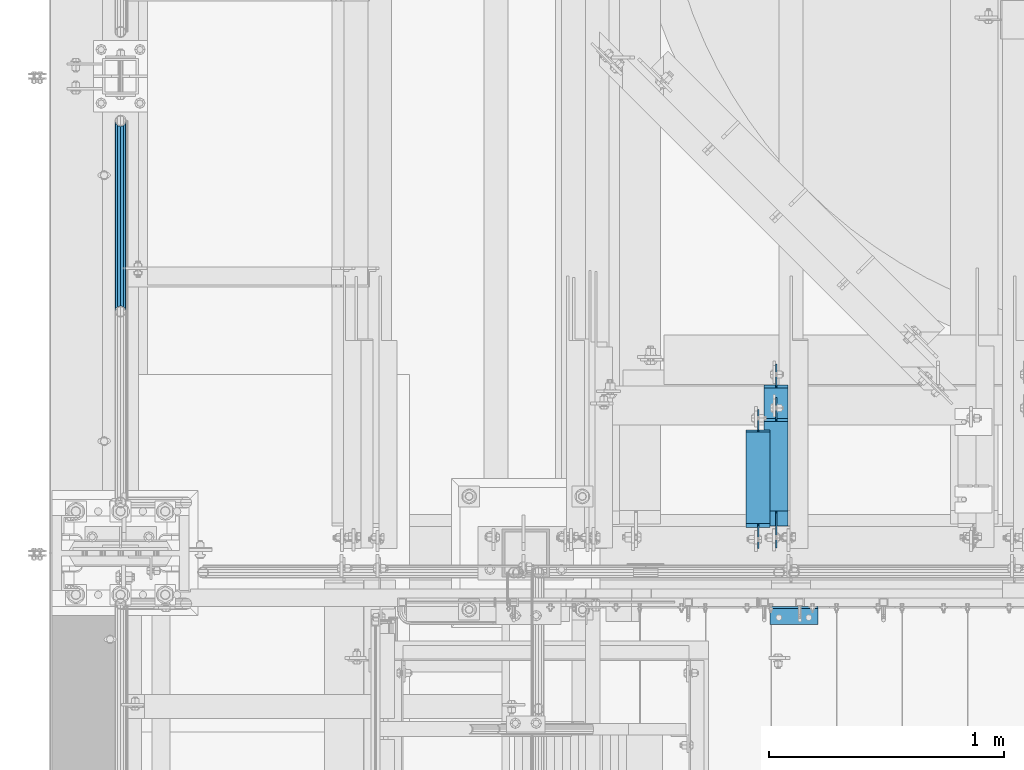
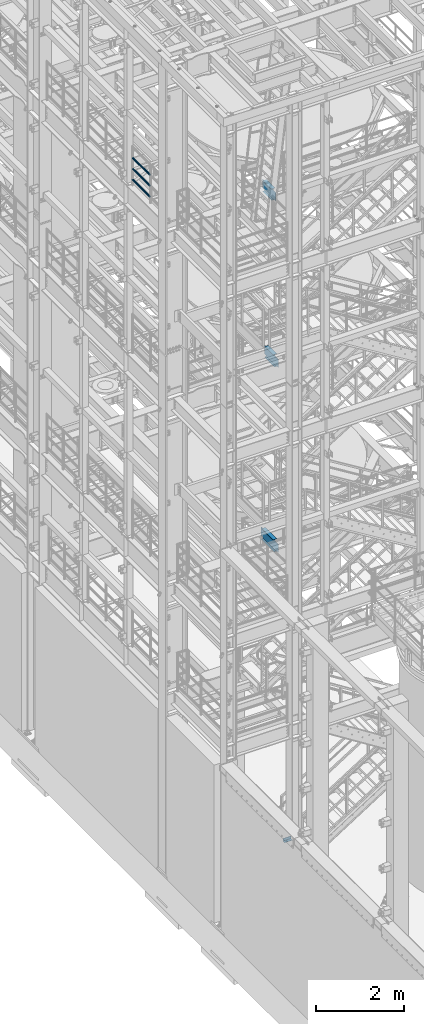
# One storey, part 1178 of 1876: 7 beams, 5 elements without a shape of their own.
"""IFC2X3 building model written with IfcOpenShell, lengths in millimetres."""

from ifc_helpers import new_model, si_unit, frame, origin_with_axes, place, context, subcontext, project, spatial, faceted_brep, material, type_object, element, aggregate, save


model = new_model("IFC2X3")

# Units and contexts
model_context = context("Model", 3, precision=1e-05, world=origin_with_axes())
body_context = subcontext(model_context, "Body", "Model", "MODEL_VIEW")
ifc_project = project(units=[si_unit("LENGTHUNIT", "METRE", prefix="MILLI"), si_unit("AREAUNIT", "SQUARE_METRE"), si_unit("VOLUMEUNIT", "CUBIC_METRE"), si_unit("MASSUNIT", "GRAM", prefix="KILO"), si_unit("TIMEUNIT", "SECOND"), si_unit("PLANEANGLEUNIT", "RADIAN"), si_unit("SOLIDANGLEUNIT", "STERADIAN"), si_unit("THERMODYNAMICTEMPERATUREUNIT", "DEGREE_CELSIUS"), si_unit("LUMINOUSINTENSITYUNIT", "LUMEN")], contexts=[model_context])

# Site, building, storey
site_placement = place(None, origin_with_axes())
site = spatial("IfcSite", under=ifc_project, at=site_placement, CompositionType="ELEMENT")
building_placement = place(site_placement, origin_with_axes())
building = spatial("IfcBuilding", under=site, at=building_placement, Name="Undefined", CompositionType="ELEMENT")
storey_placement = place(building_placement, origin_with_axes())
storey = spatial("IfcBuildingStorey", under=building, at=storey_placement, Name="Undefined", CompositionType="ELEMENT", Elevation=0.0)

# Assembly, beams
assembly_1_placement = place(storey_placement, origin_with_axes())
assembly_1 = element("IfcElementAssembly", 1, at=assembly_1_placement, inside=storey, Name="RAIL", AssemblyPlace="NOTDEFINED", PredefinedType="RIGID_FRAME")
ifc_material_1 = material()
beam_type_1 = type_object("IfcBeamType", Name="PIPE1-1/2SCH40", PredefinedType="NOTDEFINED")
beam_1_placement = place(assembly_1_placement, frame((-1.81898940354582e-12, -2729.3062, 18145.125), z_axis=(0.0, 0.0, 1.0), x_axis=(0.0, -1.0, 0.0)))
beam_1 = element("IfcBeam", 2, at=beam_1_placement, type_object=beam_type_1, material=ifc_material_1, Name="RAIL", ObjectType="PIPE1-1/2SCH40", context=body_context, shape_type="Brep", body=[
    faceted_brep([(792.499707006684, -12.0649999999996, 20.8971929933177), (792.499707006684, -12.0650000000314, 15.8661214311469), (792.006278568813, -10.2235000000001, 17.7076214311819), (789.266900000001, -9.09494701772928e-13, 20.4470000000001), (789.266900000001, -9.09494701772928e-13, 24.130000000001), (792.00627856883, 10.2235000000001, 17.7076214311819), (792.499707006684, 12.0649999999678, 15.8661214312124), (792.499707006684, 12.0649999999996, 20.8971929933177), (813.396900000002, 24.1300000000001, 0.0), (801.331900000001, 20.8971929933186, 12.0649999999987), (801.331900000001, 20.8971929933186, -12.0649999999987), (798.142328437896, 17.7076214311801, 10.2235000000001), (800.881707006714, 20.4470000000001, 0.0), (798.142328437896, 17.7076214311801, -10.2235000000001), (792.499707006684, 12.0649999999678, -15.8661214312124), (792.499707006684, 12.0649999999996, -20.8971929933177), (792.00627856883, 10.2235000000001, -17.7076214311819), (789.266900000001, 0.0, -20.4470000000001), (789.266900000001, 0.0, -24.130000000001), (792.499707006684, -12.0650000000314, -15.8661214311469), (792.499707006684, -12.0649999999996, -20.8971929933177), (792.006278568813, -10.2235000000001, -17.7076214311819), (813.396900000002, -24.1300000000319, 0.0), (801.331900000001, -20.8971929933186, -12.0649999999987), (801.331900000001, -20.8971929933186, 12.0649999999987), (798.142328437831, -17.7076214311801, -10.2235000000001), (800.881707006651, -20.4470000000001, 0.0), (798.142328437831, -17.7076214311801, 10.2235000000001), (12.0650000000064, -20.8971929933177, -12.0649999999987), (20.8971929933249, -12.0650000000005, -20.8971929933177), (0.0, 24.1299999999992, 0.0), (12.0650000000064, 20.8971929933177, -12.0649999999987), (12.0650000000064, 20.8971929933177, 12.0649999999987), (20.8971929933249, 12.0650000000005, 20.8971929933177), (24.1300000000064, 0.0, 24.130000000001), (20.8971929933249, 12.0650000000005, -20.8971929933177), (24.1300000000063, 0.0, -24.130000000001), (24.1300000000063, 0.0, -20.4470000000001), (20.8971929933249, -12.0650000000005, -15.8661214311796), (21.3906214311868, -10.2235000000001, -17.7076214311819), (21.3906214311868, 10.2235000000001, -17.7076214311819), (20.8971929933249, 12.0650000000005, -15.8661214311796), (15.2545715621445, 17.7076214311801, -10.2235000000001), (12.5151929933249, 20.4470000000001, 0.0), (15.2545715621445, 17.7076214311801, 10.2235000000001), (20.8971929933249, 12.0650000000005, 15.8661214311796), (21.3906214311868, 10.2235000000001, 17.7076214311819), (24.1300000000064, 0.0, 20.4470000000001), (21.3906214311868, -10.2235000000001, 17.7076214311819), (20.8971929933249, -12.0650000000005, 15.8661214311796), (20.8971929933249, -12.0650000000005, 20.8971929933177), (12.0650000000064, -20.8971929933177, 12.0649999999987), (0.0, -24.1299999999992, 0.0), (15.2545715621445, -17.7076214311801, 10.2235000000001), (12.5151929933249, -20.4470000000001, 0.0), (15.2545715621445, -17.7076214311801, -10.2235000000001)], [[[0, 1, 2, 3, 4]], [[4, 3, 5, 6, 7]], [[8, 9, 10]], [[7, 6, 11, 12, 13, 14, 15, 10, 9]], [[16, 17, 18, 15, 14]], [[19, 20, 18, 17, 21]], [[22, 23, 24]], [[24, 23, 20, 19, 25, 26, 27, 1, 0]], [[28, 29, 20, 23]], [[30, 31, 32]], [[33, 34, 4, 7]], [[32, 33, 7, 9]], [[30, 32, 9, 8]], [[31, 30, 8, 10]], [[35, 31, 10, 15]], [[36, 35, 15, 18]], [[29, 36, 18, 20]], [[37, 36, 29, 38, 39]], [[40, 41, 35, 36, 37]], [[32, 31, 35, 41, 42, 43, 44, 45, 33]], [[33, 45, 46, 47, 34]], [[34, 47, 48, 49, 50]], [[34, 50, 0, 4]], [[50, 51, 24, 0]], [[51, 52, 22, 24]], [[52, 28, 23, 22]], [[51, 28, 52]], [[50, 49, 53, 54, 55, 38, 29, 28, 51]], [[55, 54, 26, 25]], [[21, 39, 38, 55, 25, 19]], [[37, 39, 21, 17]], [[40, 37, 17, 16]], [[42, 41, 40, 16, 14, 13]], [[43, 42, 13, 12]], [[44, 43, 12, 11]], [[5, 46, 45, 44, 11, 6]], [[47, 46, 5, 3]], [[48, 47, 3, 2]], [[53, 49, 48, 2, 1, 27]], [[54, 53, 27, 26]]]),
])
beam_2_placement = place(assembly_1_placement, frame((-1.81898940354586e-12, -3542.7031, 18449.925), z_axis=(0.0, 0.0, -1.0), x_axis=(0.0, 1.0, 0.0)))
beam_2 = element("IfcBeam", 3, at=beam_2_placement, type_object=beam_type_1, material=ifc_material_1, Name="RAIL", ObjectType="PIPE1-1/2SCH40", context=body_context, shape_type="Brep", body=[
    faceted_brep([(0.0, 24.1299999999992, 0.0), (12.0650000000064, 20.8971929933177, -12.0649999999987), (12.0650000000064, 20.8971929933177, 12.0649999999987), (12.0650000000064, -20.8971929933177, 12.0649999999987), (12.0650000000064, -20.8971929933177, -12.0649999999987), (0.0, -24.1299999999992, 0.0), (20.8971929933249, -12.0650000000005, 20.8971929933177), (20.8971929933249, -12.0650000000005, 15.8661214311796), (15.2545715621445, -17.7076214311801, 10.2235000000001), (12.5151929933249, -20.4470000000001, 0.0), (15.2545715621445, -17.7076214311801, -10.2235000000001), (20.8971929933249, -12.0650000000005, -15.8661214311796), (20.8971929933249, -12.0650000000005, -20.8971929933177), (24.1300000000063, 0.0, -20.4470000000001), (24.1300000000063, 0.0, -24.130000000001), (21.3906214311868, -10.2235000000001, -17.7076214311819), (21.3906214311868, 10.2235000000001, -17.7076214311819), (20.8971929933249, 12.0650000000005, -15.8661214311796), (20.8971929933249, 12.0650000000005, -20.8971929933177), (15.2545715621445, 17.7076214311801, -10.2235000000001), (12.5151929933249, 20.4470000000001, 0.0), (15.2545715621445, 17.7076214311801, 10.2235000000001), (20.8971929933249, 12.0650000000005, 15.8661214311796), (20.8971929933249, 12.0650000000005, 20.8971929933177), (21.3906214311868, 10.2235000000001, 17.7076214311819), (24.1300000000064, 0.0, 20.4470000000001), (24.1300000000064, 0.0, 24.130000000001), (21.3906214311868, -10.2235000000001, 17.7076214311819), (813.396900000002, 24.1300000000001, 0.0), (801.331900000001, 20.8971929933186, -12.0649999999987), (792.499707006684, 12.0649999999996, -20.8971929933177), (813.396900000002, -24.1300000000319, 0.0), (801.331900000001, -20.8971929933186, -12.0649999999987), (801.331900000001, -20.8971929933186, 12.0649999999987), (792.499707006684, -12.0649999999996, 20.8971929933177), (792.499707006684, -12.0649999999996, -20.8971929933177), (789.266900000001, 0.0, -24.130000000001), (792.00627856883, 10.2235000000001, -17.7076214311819), (789.266900000001, 0.0, -20.4470000000001), (792.499707006684, 12.0649999999678, -15.8661214312124), (792.499707006684, -12.0650000000314, -15.8661214311469), (792.006278568813, -10.2235000000001, -17.7076214311819), (798.142328437831, -17.7076214311801, -10.2235000000001), (800.881707006651, -20.4470000000001, 0.0), (798.142328437831, -17.7076214311801, 10.2235000000001), (792.499707006684, -12.0650000000314, 15.8661214311469), (792.006278568813, -10.2235000000001, 17.7076214311819), (789.266900000001, -9.09494701772928e-13, 20.4470000000001), (789.266900000001, -9.09494701772928e-13, 24.130000000001), (792.499707006684, 12.0649999999996, 20.8971929933177), (801.331900000001, 20.8971929933186, 12.0649999999987), (792.499707006684, 12.0649999999678, 15.8661214312124), (798.142328437896, 17.7076214311801, 10.2235000000001), (800.881707006714, 20.4470000000001, 0.0), (798.142328437896, 17.7076214311801, -10.2235000000001), (792.00627856883, 10.2235000000001, 17.7076214311819)], [[[0, 1, 2]], [[3, 4, 5]], [[6, 7, 8, 9, 10, 11, 12, 4, 3]], [[13, 14, 12, 11, 15]], [[16, 17, 18, 14, 13]], [[2, 1, 18, 17, 19, 20, 21, 22, 23]], [[23, 22, 24, 25, 26]], [[26, 25, 27, 7, 6]], [[1, 0, 28, 29]], [[18, 1, 29, 30]], [[31, 32, 33]], [[6, 3, 33, 34]], [[3, 5, 31, 33]], [[5, 4, 32, 31]], [[4, 12, 35, 32]], [[12, 14, 36, 35]], [[14, 18, 30, 36]], [[37, 38, 36, 30, 39]], [[40, 35, 36, 38, 41]], [[33, 32, 35, 40, 42, 43, 44, 45, 34]], [[34, 45, 46, 47, 48]], [[26, 6, 34, 48]], [[2, 23, 49, 50]], [[23, 26, 48, 49]], [[0, 2, 50, 28]], [[28, 50, 29]], [[49, 51, 52, 53, 54, 39, 30, 29, 50]], [[48, 47, 55, 51, 49]], [[25, 24, 55, 47]], [[55, 24, 22, 21, 52, 51]], [[21, 20, 53, 52]], [[20, 19, 54, 53]], [[19, 17, 16, 37, 39, 54]], [[16, 13, 38, 37]], [[13, 15, 41, 38]], [[41, 15, 11, 10, 42, 40]], [[10, 9, 43, 42]], [[9, 8, 44, 43]], [[8, 7, 27, 46, 45, 44]], [[27, 25, 47, 46]]]),
])
beam_3_placement = place(assembly_1_placement, frame((-1.81898940354586e-12, -3542.7031, 18754.725), z_axis=(0.0, 0.0, -1.0), x_axis=(0.0, 1.0, 0.0)))
beam_3 = element("IfcBeam", 4, at=beam_3_placement, type_object=beam_type_1, material=ifc_material_1, Name="RAIL", ObjectType="PIPE1-1/2SCH40", context=body_context, shape_type="Brep", body=[
    faceted_brep([(0.0, 24.1299999999992, 0.0), (12.0650000000064, 20.8971929933177, -12.0649999999987), (12.0650000000064, 20.8971929933177, 12.0649999999987), (12.0650000000064, -20.8971929933177, 12.0649999999987), (12.0650000000064, -20.8971929933177, -12.0649999999987), (0.0, -24.1299999999992, 0.0), (20.8971929933249, -12.0650000000005, 20.8971929933177), (20.8971929933249, -12.0650000000005, 15.8661214311796), (15.2545715621445, -17.7076214311801, 10.2235000000001), (12.5151929933249, -20.4470000000001, 0.0), (15.2545715621445, -17.7076214311801, -10.2235000000001), (20.8971929933249, -12.0650000000005, -15.8661214311796), (20.8971929933249, -12.0650000000005, -20.8971929933177), (24.1300000000063, 0.0, -20.4470000000001), (24.1300000000063, 0.0, -24.130000000001), (21.3906214311868, -10.2235000000001, -17.7076214311819), (21.3906214311868, 10.2235000000001, -17.7076214311819), (20.8971929933249, 12.0650000000005, -15.8661214311796), (20.8971929933249, 12.0650000000005, -20.8971929933177), (15.2545715621445, 17.7076214311801, -10.2235000000001), (12.5151929933249, 20.4470000000001, 0.0), (15.2545715621445, 17.7076214311801, 10.2235000000001), (20.8971929933249, 12.0650000000005, 15.8661214311796), (20.8971929933249, 12.0650000000005, 20.8971929933177), (21.3906214311868, 10.2235000000001, 17.7076214311819), (24.1300000000064, 0.0, 20.4470000000001), (24.1300000000064, 0.0, 24.130000000001), (21.3906214311868, -10.2235000000001, 17.7076214311819), (813.396900000002, 24.1300000000001, 0.0), (801.331900000001, 20.8971929933186, -12.0649999999987), (792.499707006684, 12.0649999999996, -20.8971929933177), (813.396900000002, -24.1300000000319, 0.0), (801.331900000001, -20.8971929933186, -12.0649999999987), (801.331900000001, -20.8971929933186, 12.0649999999987), (792.499707006684, -12.0649999999996, 20.8971929933177), (792.499707006684, -12.0649999999996, -20.8971929933177), (789.266900000001, 0.0, -24.130000000001), (792.00627856883, 10.2235000000001, -17.7076214311819), (789.266900000001, 0.0, -20.4470000000001), (792.499707006684, 12.0649999999678, -15.8661214312124), (792.499707006684, -12.0650000000314, -15.8661214311469), (792.006278568813, -10.2235000000001, -17.7076214311819), (798.142328437831, -17.7076214311801, -10.2235000000001), (800.881707006651, -20.4470000000001, 0.0), (798.142328437831, -17.7076214311801, 10.2235000000001), (792.499707006684, -12.0650000000314, 15.8661214311469), (792.006278568813, -10.2235000000001, 17.7076214311819), (789.266900000001, -9.09494701772928e-13, 20.4470000000001), (789.266900000001, -9.09494701772928e-13, 24.130000000001), (792.499707006684, 12.0649999999996, 20.8971929933177), (801.331900000001, 20.8971929933186, 12.0649999999987), (792.499707006684, 12.0649999999678, 15.8661214312124), (798.142328437896, 17.7076214311801, 10.2235000000001), (800.881707006714, 20.4470000000001, 0.0), (798.142328437896, 17.7076214311801, -10.2235000000001), (792.00627856883, 10.2235000000001, 17.7076214311819)], [[[0, 1, 2]], [[3, 4, 5]], [[6, 7, 8, 9, 10, 11, 12, 4, 3]], [[13, 14, 12, 11, 15]], [[16, 17, 18, 14, 13]], [[2, 1, 18, 17, 19, 20, 21, 22, 23]], [[23, 22, 24, 25, 26]], [[26, 25, 27, 7, 6]], [[1, 0, 28, 29]], [[18, 1, 29, 30]], [[31, 32, 33]], [[6, 3, 33, 34]], [[3, 5, 31, 33]], [[5, 4, 32, 31]], [[4, 12, 35, 32]], [[12, 14, 36, 35]], [[14, 18, 30, 36]], [[37, 38, 36, 30, 39]], [[40, 35, 36, 38, 41]], [[33, 32, 35, 40, 42, 43, 44, 45, 34]], [[34, 45, 46, 47, 48]], [[26, 6, 34, 48]], [[2, 23, 49, 50]], [[23, 26, 48, 49]], [[0, 2, 50, 28]], [[28, 50, 29]], [[49, 51, 52, 53, 54, 39, 30, 29, 50]], [[48, 47, 55, 51, 49]], [[25, 24, 55, 47]], [[55, 24, 22, 21, 52, 51]], [[21, 20, 53, 52]], [[20, 19, 54, 53]], [[19, 17, 16, 37, 39, 54]], [[16, 13, 38, 37]], [[13, 15, 41, 38]], [[41, 15, 11, 10, 42, 40]], [[10, 9, 43, 42]], [[9, 8, 44, 43]], [[8, 7, 27, 46, 45, 44]], [[27, 25, 47, 46]]]),
])
aggregate(assembly_1, [beam_1, beam_2, beam_3])

# Assembly, beam
assembly_2_placement = place(storey_placement, origin_with_axes())
assembly_2 = element("IfcElementAssembly", 5, at=assembly_2_placement, inside=storey, Name="BEAM", AssemblyPlace="NOTDEFINED", PredefinedType="RIGID_FRAME")
ifc_material_2 = material(Name="STEEL/A992")
beam_type_2 = type_object("IfcBeamType", Name="W12X16", PredefinedType="NOTDEFINED")
beam_4_placement = place(assembly_2_placement, frame((2717.8, -4572.0, 17830.8), z_axis=(0.0, 0.0, 1.0), x_axis=(0.0, 1.0, 0.0)))
beam_4 = element("IfcBeam", 6, at=beam_4_placement, type_object=beam_type_2, material=ifc_material_2, Name="BEAM", ObjectType="W12X16", context=body_context, shape_type="Brep", body=[
    faceted_brep([(523.875, -3.17500000000018, -146.049999999999), (523.875, -50.8000000000002, -146.049999999999), (523.875, -50.8000000000002, -152.400000000001), (523.875, 50.8000000000002, -152.400000000001), (523.875, 50.8000000000002, -146.049999999999), (523.875, 3.17500001640747, -146.049999999999), (523.875, 3.17500003437635, -139.699999809272), (523.875, -3.17500000000018, -139.699999809272), (524.841729922588, 3.17500003361238, -134.839920291226), (524.841729922588, -3.17500000000018, -134.839920291226), (527.594743823066, 3.17500003295299, -130.719743823072), (527.594743823066, -3.17500000000018, -130.719743823072), (531.714920291219, 3.17500003250007, -127.966729922595), (531.714920291219, -3.17500000000018, -127.966729922595), (536.574999809265, 3.1750000323218, -127.000000000007), (536.574999809265, -3.17500000000018, -127.000000000007), (612.775, -3.17500000000018, -127.000000000007), (612.775, 3.17500000000018, -127.000000000007), (126.20625, 3.17499999999995, 146.049999999999), (126.20625, 50.8, 146.049999999999), (515.9375, 50.8000000000002, 146.049999999999), (515.9375, 3.17500000000018, 146.049999999999), (108.74375, -3.17499999999995, -139.699999809261), (108.74375, 3.17500002570978, -139.699999809261), (108.74375, 3.17500009516311, -146.049999999999), (108.74375, 50.8, -146.049999999999), (108.74375, 50.8, -152.400000000001), (108.74375, -50.8, -152.400000000001), (108.74375, -50.8, -146.049999999999), (108.74375, -3.17499999999995, -146.049999999999), (107.777020077412, -3.17499999999995, -134.839920291215), (107.777020077412, 3.17500002492102, -134.839920291215), (105.024006176934, -3.17499999999995, -130.719743823061), (105.024006176934, 3.17500002425209, -130.719743823061), (100.90382970878, -3.17499999999995, -127.966729922584), (100.90382970878, 3.17500002380461, -127.966729922584), (96.0437501907345, -3.17499999999995, -126.999999999996), (96.0437501907345, 3.17500002364682, -126.999999999996), (19.84375, -3.17499999999995, -126.999999999996), (19.84375, 3.17499999999995, -126.999999999996), (19.84375, -3.17499999999995, 107.950000000004), (19.84375, 3.17499999999995, 107.950000000004), (113.506250190735, -3.17499999999995, 107.950000000004), (113.506250190735, 3.17499998606149, 107.950000000004), (118.366329708781, -3.17499999999995, 108.916729922592), (118.366329708781, 3.17499998590552, 108.916729922592), (122.486506176934, -3.17499999999995, 111.669743823069), (122.486506176934, 3.17499998546009, 111.669743823069), (125.239520077413, -3.17499999999995, 115.789920291223), (125.239520077413, 3.17499998479298, 115.789920291223), (126.20625, -3.17499999999995, 120.64999980927), (126.20625, 3.17499998400558, 120.64999980927), (126.20625, 50.8, 152.400000000001), (126.20625, -50.8, 152.400000000001), (515.9375, -50.8000000000002, 152.400000000001), (515.9375, 50.8000000000002, 152.400000000001), (126.20625, -50.8, 146.049999999999), (515.9375, -50.8000000000002, 146.049999999999), (126.20625, -3.17499999999995, 146.049999999999), (515.9375, -3.17500000000018, 146.049999999999), (515.9375, -3.17500000000018, 133.349999809259), (515.9375, 3.17499999236406, 133.349999809259), (516.904229922588, -3.17500000000018, 128.489920291213), (516.904229922588, 3.17499999310803, 128.489920291213), (519.657243823066, -3.17500000000018, 124.369743823059), (519.657243823066, 3.17499999372922, 124.369743823059), (523.777420291219, -3.17500000000018, 121.616729922582), (523.777420291219, 3.17499999413303, 121.616729922582), (528.637499809265, -3.17500000000018, 120.649999999994), (528.637499809265, 3.17499999425763, 120.649999999994), (612.775, -3.17500000000018, 120.649999999994), (612.775, 3.17500000000018, 120.649999999994)], [[[0, 1, 2, 3, 4, 5, 6, 7]], [[7, 6, 8, 9]], [[9, 8, 10, 11]], [[11, 10, 12, 13]], [[13, 12, 14, 15]], [[16, 15, 14, 17]], [[18, 19, 20, 21]], [[22, 23, 24, 25, 26, 27, 28, 29]], [[30, 31, 23, 22]], [[32, 33, 31, 30]], [[34, 35, 33, 32]], [[36, 37, 35, 34]], [[38, 39, 37, 36]], [[40, 41, 39, 38]], [[42, 43, 41, 40]], [[44, 45, 43, 42]], [[46, 47, 45, 44]], [[48, 49, 47, 46]], [[50, 51, 49, 48]], [[52, 53, 54, 55]], [[53, 56, 57, 54]], [[56, 58, 59, 57]], [[53, 52, 19, 18, 51, 50, 58, 56]], [[19, 52, 55, 20]], [[54, 57, 59, 60, 61, 21, 20, 55]], [[62, 63, 61, 60]], [[64, 65, 63, 62]], [[66, 67, 65, 64]], [[68, 69, 67, 66]], [[70, 71, 69, 68]], [[71, 70, 16, 17]], [[12, 10, 8, 6, 5, 24, 23, 31, 33, 35, 37, 39, 41, 43, 45, 47, 49, 51, 18, 21, 61, 63, 65, 67, 69, 71, 17, 14]], [[25, 24, 5, 4]], [[26, 25, 4, 3]], [[27, 26, 3, 2]], [[28, 27, 2, 1]], [[29, 28, 1, 0]], [[70, 68, 66, 64, 62, 60, 59, 58, 50, 48, 46, 44, 42, 40, 38, 36, 34, 32, 30, 22, 29, 0, 7, 9, 11, 13, 15, 16]]]),
])
aggregate(assembly_2, [beam_4])

assembly_3_placement = place(storey_placement, origin_with_axes())
assembly_3 = element("IfcElementAssembly", 7, at=assembly_3_placement, inside=storey, Name="BEAM", AssemblyPlace="NOTDEFINED", PredefinedType="RIGID_FRAME")
beam_5_placement = place(assembly_3_placement, frame((2794.0, -4572.0, 13157.2), z_axis=(0.0, 0.0, 1.0), x_axis=(0.0, 1.0, 0.0)))
beam_5 = element("IfcBeam", 8, at=beam_5_placement, type_object=beam_type_2, material=ifc_material_2, Name="BEAM", ObjectType="W12X16", context=body_context, shape_type="Brep", body=[
    faceted_brep([(573.881250000001, -3.17500000000018, -146.049999999999), (573.881250000001, -50.8000000000002, -146.049999999999), (573.881250000001, -50.8000000000002, -152.4), (573.881250000001, 50.8000000000002, -152.4), (573.881250000001, 50.8000000000002, -146.049999999999), (573.881250000001, 3.17500000000018, -146.049999999999), (573.881250000001, 3.17500000000018, -139.699999809265), (573.881250000001, -3.17500000000018, -139.699999809265), (574.847979922589, 3.17500000000018, -134.839920291219), (574.847979922589, -3.17500000000018, -134.839920291219), (577.600993823067, 3.17500000000018, -130.719743823065), (577.600993823067, -3.17500000000018, -130.719743823065), (581.72117029122, 3.17500000000018, -127.966729922588), (581.72117029122, -3.17500000000018, -127.966729922588), (586.581249809266, 3.17500000000018, -127.0), (586.581249809266, -3.17500000000018, -127.0), (662.78125, -3.17500000000018, -127.0), (662.78125, 3.17500000000018, -127.0), (179.3875, 3.17500000000018, 146.049999999999), (179.3875, 50.8000000000002, 146.049999999999), (561.181250000001, 50.8000000000002, 146.049999999999), (561.181250000001, 3.17500000000018, 146.049999999999), (115.8875, -3.17500000000018, -139.699999809263), (115.8875, 3.17500000000018, -139.699999809263), (115.8875, 3.17500000000018, -146.049999999999), (115.8875, 50.8000000000002, -146.049999999999), (115.8875, 50.8000000000002, -152.4), (115.8875, -50.8000000000002, -152.4), (115.8875, -50.8000000000002, -146.049999999999), (115.8875, -3.17500000000018, -146.049999999999), (114.920770077412, -3.17500000000018, -134.839920291217), (114.920770077412, 3.17500000000018, -134.839920291217), (112.167756176934, -3.17500000000018, -130.719743823063), (112.167756176934, 3.17500000000018, -130.719743823063), (108.04757970878, -3.17500000000018, -127.966729922586), (108.04757970878, 3.17500000000018, -127.966729922586), (103.187500190735, -3.17500000000018, -126.999999999998), (103.187500190735, 3.17500000000018, -126.999999999998), (20.6374999999998, -3.17500000000018, -126.999999999998), (20.6374999999998, 3.17500000000018, -126.999999999998), (20.6374999999998, -3.17500000000018, 101.600000000002), (20.6374999999998, 3.17500000000018, 101.600000000002), (166.687500190735, -3.17500000000018, 101.600000000002), (166.687500190735, 3.17500000000018, 101.600000000002), (171.54757970878, -3.17500000000018, 102.56672992259), (171.54757970878, 3.17500000000018, 102.56672992259), (175.667756176934, -3.17500000000018, 105.319743823067), (175.667756176934, 3.17500000000018, 105.319743823067), (178.420770077412, -3.17500000000018, 109.439920291221), (178.420770077412, 3.17500000000018, 109.439920291221), (179.3875, -3.17500000000018, 114.299999809267), (179.3875, 3.17500000000018, 114.299999809267), (179.3875, -50.8000000000002, 152.4), (179.3875, 50.8000000000002, 152.4), (179.3875, -3.17500000000018, 146.049999999999), (179.3875, -50.8000000000002, 146.049999999999), (561.181250000001, -3.17500000000018, 146.049999999999), (561.181250000001, -50.8000000000002, 146.049999999999), (561.181250000001, -50.8000000000002, 152.4), (561.181250000001, 50.8000000000002, 152.4), (561.181250000001, -3.17500000000018, 133.349999809265), (561.181250000001, 3.17500000000018, 133.349999809265), (562.147979922589, -3.17500000000018, 128.489920291218), (562.147979922589, 3.17500000000018, 128.489920291218), (564.900993823067, -3.17500000000018, 124.369743823065), (564.900993823067, 3.17500000000018, 124.369743823065), (569.021170291221, -3.17500000000018, 121.616729922587), (569.021170291221, 3.17500000000018, 121.616729922587), (573.881249809266, -3.17500000000018, 120.65), (573.881249809266, 3.17500000000018, 120.65), (662.78125, -3.17500000000018, 120.65), (662.78125, 3.17500000000018, 120.65)], [[[0, 1, 2, 3, 4, 5, 6, 7]], [[7, 6, 8, 9]], [[9, 8, 10, 11]], [[11, 10, 12, 13]], [[13, 12, 14, 15]], [[16, 15, 14, 17]], [[18, 19, 20, 21]], [[22, 23, 24, 25, 26, 27, 28, 29]], [[30, 31, 23, 22]], [[32, 33, 31, 30]], [[34, 35, 33, 32]], [[36, 37, 35, 34]], [[38, 39, 37, 36]], [[40, 41, 39, 38]], [[42, 43, 41, 40]], [[44, 45, 43, 42]], [[46, 47, 45, 44]], [[48, 49, 47, 46]], [[50, 51, 49, 48]], [[52, 53, 19, 18, 51, 50, 54, 55]], [[55, 54, 56, 57]], [[52, 55, 57, 58]], [[53, 52, 58, 59]], [[19, 53, 59, 20]], [[58, 57, 56, 60, 61, 21, 20, 59]], [[62, 63, 61, 60]], [[64, 65, 63, 62]], [[66, 67, 65, 64]], [[68, 69, 67, 66]], [[70, 71, 69, 68]], [[71, 70, 16, 17]], [[12, 10, 8, 6, 5, 24, 23, 31, 33, 35, 37, 39, 41, 43, 45, 47, 49, 51, 18, 21, 61, 63, 65, 67, 69, 71, 17, 14]], [[25, 24, 5, 4]], [[26, 25, 4, 3]], [[27, 26, 3, 2]], [[28, 27, 2, 1]], [[29, 28, 1, 0]], [[70, 68, 66, 64, 62, 60, 56, 54, 50, 48, 46, 44, 42, 40, 38, 36, 34, 32, 30, 22, 29, 0, 7, 9, 11, 13, 15, 16]]]),
])
aggregate(assembly_3, [beam_5])

assembly_4_placement = place(storey_placement, origin_with_axes())
assembly_4 = element("IfcElementAssembly", 9, at=assembly_4_placement, inside=storey, Name="BEAM", AssemblyPlace="NOTDEFINED", PredefinedType="RIGID_FRAME")
beam_6_placement = place(assembly_4_placement, frame((2794.0, -4572.0, 8001.0), z_axis=(0.0, 0.0, 1.0), x_axis=(0.0, 1.0, 0.0)))
beam_6 = element("IfcBeam", 10, at=beam_6_placement, type_object=beam_type_2, material=ifc_material_2, Name="BEAM", ObjectType="W12X16", context=body_context, shape_type="Brep", body=[
    faceted_brep([(716.75625, -3.17500000000018, -146.05), (716.75625, -50.8000000000002, -146.05), (716.75625, -50.8000000000002, -152.4), (716.75625, 50.8000000000002, -152.4), (716.75625, 50.8000000000002, -146.05), (716.75625, 3.17500001244935, -146.05), (716.75625, 3.17500003927307, -139.699999809264), (716.75625, -3.17500000000018, -139.699999809264), (717.722979922588, 3.17500003847817, -134.839920291219), (717.722979922588, -3.17500000000018, -134.839920291219), (720.475993823066, 3.17500003779696, -130.719743823065), (720.475993823066, -3.17500000000018, -130.719743823065), (724.59617029122, 3.17500003733312, -127.966729922587), (724.59617029122, -3.17500000000018, -127.966729922587), (729.456249809265, 3.17500003715577, -126.999999999999), (729.456249809265, -3.17500000000018, -126.999999999999), (805.65625, -3.17500000000018, -126.999999999999), (805.65625, 3.17500000000018, -126.999999999999), (181.768749999998, 3.17499999999995, 146.05), (181.768749999998, 50.8, 146.05), (704.05625, 50.8000000000002, 146.05), (704.05625, 3.17500000000018, 146.05), (124.61875, 50.8, -146.05), (124.61875, 50.8, -152.4), (124.61875, 3.17500009536752, -152.4), (124.61875, 3.17500009536752, -146.05), (118.268749999998, 3.17500009536752, -152.4), (118.268749999998, 3.17500008940715, -146.05), (118.268749999998, -3.17499999999995, -139.699999809265), (118.268749999998, 3.17500002616043, -139.699999809265), (118.268749999998, -50.8, -152.4), (118.268749999998, -50.8, -146.05), (118.268749999998, -3.17499999999995, -146.05), (117.302020077411, -3.17499999999995, -134.83992029122), (117.302020077411, 3.17500002537099, -134.83992029122), (114.549006176932, -3.17499999999995, -130.719743823066), (114.549006176932, 3.17500002470138, -130.719743823066), (110.428829708779, -3.17499999999995, -127.966729922588), (110.428829708779, 3.17500002425345, -127.966729922588), (105.568750190733, -3.17499999999995, -127.0), (105.568750190733, 3.17500002409543, -127.0), (23.0187500000002, -3.17499999999995, -127.0), (23.0187500000002, 3.17499999999995, -127.0), (23.0187500000002, -3.17499999999995, 101.6), (23.0187500000002, 3.17499999999995, 101.6), (169.068750190733, -3.17499999999995, 101.6), (169.068750190733, 3.17499998798007, 101.6), (173.928829708779, -3.17499999999995, 102.566729922588), (173.928829708779, 3.17499998782432, 102.566729922588), (178.049006176932, -3.17499999999995, 105.319743823066), (178.049006176932, 3.17499998738072, 105.319743823066), (180.802020077411, -3.17499999999995, 109.43992029122), (180.802020077411, 3.17499998671678, 109.43992029122), (181.768749999998, -3.17499999999995, 114.299999809266), (181.768749999998, 3.17499998593348, 114.299999809266), (181.768749999998, -50.8, 152.4), (181.768749999998, 50.8, 152.4), (181.768749999998, -3.17499999999995, 146.05), (181.768749999998, -50.8, 146.05), (704.05625, -3.17500000000018, 146.05), (704.05625, -50.8000000000002, 146.05), (704.05625, -50.8000000000002, 152.4), (704.05625, 50.8000000000002, 152.4), (704.05625, -3.17500000000018, 133.349999809266), (704.05625, 3.1749999952408, 133.349999809266), (705.022979922588, -3.17500000000018, 128.48992029122), (705.022979922588, 3.17499999601478, 128.48992029122), (707.775993823066, -3.17500000000018, 124.369743823067), (707.775993823066, 3.17499999666416, 124.369743823067), (711.89617029122, -3.17500000000018, 121.616729922588), (711.89617029122, 3.1749999970898, 121.616729922588), (716.756249809265, -3.17500000000018, 120.650000000001), (716.756249809265, 3.17499999722713, 120.650000000001), (805.65625, -3.17500000000018, 120.650000000001), (805.65625, 3.17500000000018, 120.650000000001)], [[[0, 1, 2, 3, 4, 5, 6, 7]], [[7, 6, 8, 9]], [[9, 8, 10, 11]], [[11, 10, 12, 13]], [[13, 12, 14, 15]], [[16, 15, 14, 17]], [[18, 19, 20, 21]], [[22, 23, 24, 25]], [[25, 24, 26, 27]], [[28, 29, 27, 26, 30, 31, 32]], [[33, 34, 29, 28]], [[35, 36, 34, 33]], [[37, 38, 36, 35]], [[39, 40, 38, 37]], [[41, 42, 40, 39]], [[43, 44, 42, 41]], [[45, 46, 44, 43]], [[47, 48, 46, 45]], [[49, 50, 48, 47]], [[51, 52, 50, 49]], [[53, 54, 52, 51]], [[55, 56, 19, 18, 54, 53, 57, 58]], [[58, 57, 59, 60]], [[55, 58, 60, 61]], [[56, 55, 61, 62]], [[19, 56, 62, 20]], [[61, 60, 59, 63, 64, 21, 20, 62]], [[65, 66, 64, 63]], [[67, 68, 66, 65]], [[69, 70, 68, 67]], [[71, 72, 70, 69]], [[73, 74, 72, 71]], [[74, 73, 16, 17]], [[12, 10, 8, 6, 5, 25, 27, 29, 34, 36, 38, 40, 42, 44, 46, 48, 50, 52, 54, 18, 21, 64, 66, 68, 70, 72, 74, 17, 14]], [[22, 25, 5, 4]], [[23, 22, 4, 3]], [[30, 26, 24, 23, 3, 2]], [[31, 30, 2, 1]], [[32, 31, 1, 0]], [[73, 71, 69, 67, 65, 63, 59, 57, 53, 51, 49, 47, 45, 43, 41, 39, 37, 35, 33, 28, 32, 0, 7, 9, 11, 13, 15, 16]]]),
])
aggregate(assembly_4, [beam_6])

assembly_5_placement = place(storey_placement, origin_with_axes())
assembly_5 = element("IfcElementAssembly", 11, at=assembly_5_placement, inside=storey, Name="STRINGER", AssemblyPlace="NOTDEFINED", PredefinedType="RIGID_FRAME")
ifc_material_3 = material(Name="STEEL/A36")
beam_type_3 = type_object("IfcBeamType", Name="L3X3X5/16", PredefinedType="NOTDEFINED")
beam_7_placement = place(assembly_5_placement, frame((2971.80000033307, -4838.70000120413, 38.0179379306484), z_axis=(0.0, -1.0, 0.0), x_axis=(-1.0, 0.0, 0.0)))
beam_7 = element("IfcBeam", 12, at=beam_7_placement, type_object=beam_type_3, material=ifc_material_3, Name="ANGLE", ObjectType="L3X3X5/16", context=body_context, shape_type="Brep", body=[
    faceted_brep([(0.0, 38.1000000000004, -38.1), (0.0, 38.1000000000004, 38.1), (203.2, 38.1, 38.1000000000004), (203.2, 38.1, -38.1000000000004), (0.0, 30.1625, 38.1000000000004), (203.2, 30.1625, 38.1000000000004), (0.0, 30.1625, -30.1625000000004), (203.2, 30.1625, -30.1625000000004), (0.0, -38.1, -30.1625000000004), (203.2, -38.1, -30.1625000000004), (0.0, -38.1000000000004, -38.1), (203.2, -38.1, -38.1000000000004)], [[[0, 1, 2, 3]], [[1, 4, 5, 2]], [[4, 6, 7, 5]], [[6, 8, 9, 7]], [[8, 10, 11, 9]], [[10, 0, 3, 11]], [[5, 7, 9, 11, 3, 2]], [[10, 8, 6, 4, 1, 0]]]),
])
aggregate(assembly_5, [beam_7])

save(model, "model.ifc")
